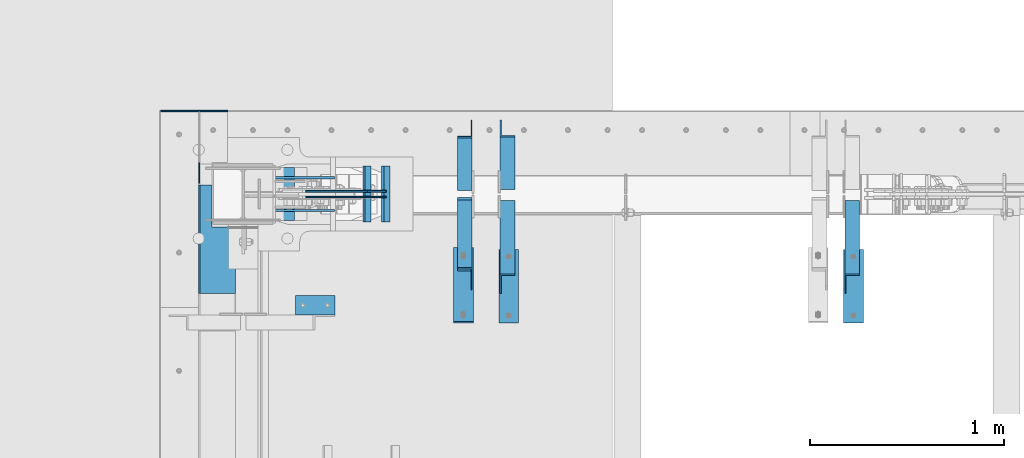
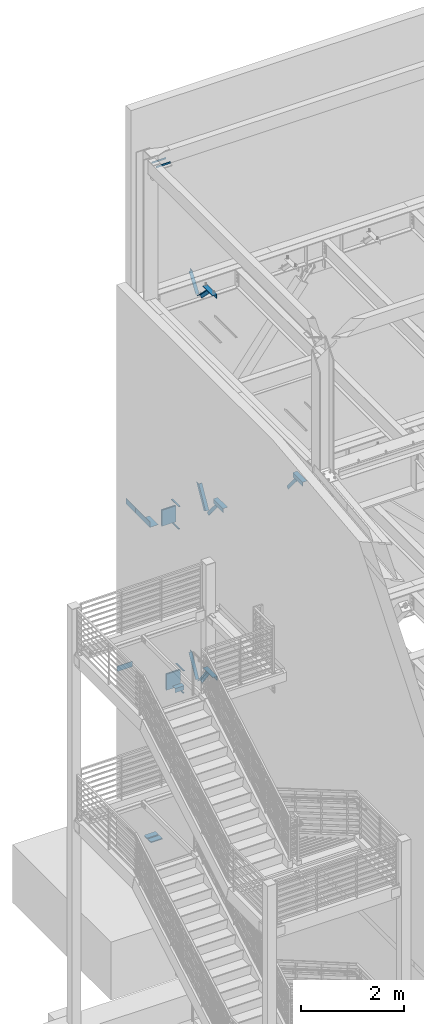
# One storey, part 882 of 1179: 20 beams, 7 members, 23 elements without a shape of their own.
"""IFC2X3 building model written with IfcOpenShell, lengths in millimetres."""

from ifc_helpers import new_model, si_unit, frame, origin_with_axes, place, context, subcontext, project, spatial, faceted_brep, material, type_object, element, aggregate, save


model = new_model("IFC2X3")

# Units and contexts
model_context = context("Model", 3, precision=1e-05, world=origin_with_axes())
body_context = subcontext(model_context, "Body", "Model", "MODEL_VIEW")
ifc_project = project(units=[si_unit("LENGTHUNIT", "METRE", prefix="MILLI"), si_unit("AREAUNIT", "SQUARE_METRE"), si_unit("VOLUMEUNIT", "CUBIC_METRE"), si_unit("MASSUNIT", "GRAM", prefix="KILO"), si_unit("TIMEUNIT", "SECOND"), si_unit("PLANEANGLEUNIT", "RADIAN"), si_unit("SOLIDANGLEUNIT", "STERADIAN"), si_unit("THERMODYNAMICTEMPERATUREUNIT", "DEGREE_CELSIUS"), si_unit("LUMINOUSINTENSITYUNIT", "LUMEN")], contexts=[model_context])

# Site, building, storey
site_placement = place(None, origin_with_axes())
site = spatial("IfcSite", under=ifc_project, at=site_placement, CompositionType="ELEMENT")
building_placement = place(site_placement, origin_with_axes())
building = spatial("IfcBuilding", under=site, at=building_placement, Name="Undefined", CompositionType="ELEMENT")
storey_placement = place(building_placement, origin_with_axes())
storey = spatial("IfcBuildingStorey", under=building, at=storey_placement, Name="Undefined", CompositionType="ELEMENT", Elevation=0.0)

# Assembly, member
assembly_1_placement = place(storey_placement, origin_with_axes())
assembly_1 = element("IfcElementAssembly", 1, at=assembly_1_placement, inside=storey, Name="ANGLE", AssemblyPlace="NOTDEFINED", PredefinedType="RIGID_FRAME")
ifc_material_1 = material(Name="STEEL/A36")
member_type = type_object("IfcMemberType", Name="L3X3X1/4", PredefinedType="NOTDEFINED")
member_1_placement = place(assembly_1_placement, frame((1574.8, 41248.3636551318, 12707.4244380128), z_axis=(0.0, 0.821716663099518, -0.569896241069015), x_axis=(0.0, 0.569896241069016, 0.821716663099518)))
member_1 = element("IfcMember", 2, at=member_1_placement, type_object=member_type, material=ifc_material_1, Name="ANGLE", ObjectType="L3X3X1/4", context=body_context, shape_type="Brep", body=[
    faceted_brep([(0.0, -38.0999999999985, -38.0999999999999), (0.0, -38.0999999999985, -31.75), (0.0, 31.75, -31.75), (0.0, 31.75, 38.1000000000004), (0.0, 38.0999999999985, 38.0999999999999), (0.0, 38.0999999999985, -38.0999999999999), (527.418547333735, 31.75, 38.0999999993364), (527.418547333735, 38.1000000000004, 38.0999999993364), (474.570533511644, 38.1000000000004, -38.1000000006607), (474.570533511644, -38.1000000000004, -38.1000000006607), (478.974534663488, -38.1000000000004, -31.7500000006621), (478.974534663488, 31.75, -31.7500000006621)], [[[0, 1, 2, 3, 4, 5]], [[4, 3, 6, 7]], [[5, 4, 7, 8]], [[0, 5, 8, 9]], [[1, 0, 9, 10]], [[2, 1, 10, 11]], [[3, 2, 11, 6]], [[10, 9, 8, 7, 6, 11]]]),
])
aggregate(assembly_1, [member_1])

assembly_2_placement = place(storey_placement, origin_with_axes())
assembly_2 = element("IfcElementAssembly", 3, at=assembly_2_placement, inside=storey, Name="ANGLE", AssemblyPlace="NOTDEFINED", PredefinedType="RIGID_FRAME")
member_2_placement = place(assembly_2_placement, frame((3573.22978739681, 41137.0679040265, 7518.83524528677), z_axis=(0.0, -0.767806695844832, -0.640681572870519), x_axis=(0.0, -0.640681572870519, 0.767806695844831)))
member_2 = element("IfcMember", 4, at=member_2_placement, type_object=member_type, material=ifc_material_1, Name="ANGLE", ObjectType="L3X3X1/4", context=body_context, shape_type="Brep", body=[
    faceted_brep([(0.0, 38.0999999999985, -38.0999999999999), (0.0, 38.0999999999985, 38.0999999999999), (655.633410548446, 38.1000000000004, 38.0999999994965), (592.049781860664, 38.1000000000004, -38.1000000005733), (0.0, 31.75, 38.1000000000004), (655.633410548446, 31.75, 38.0999999994965), (0.0, 31.75, -31.75), (597.348417584646, 31.75, -31.7500000005675), (0.0, -38.0999999999985, -31.75), (597.348417584646, -38.1000000000004, -31.7500000005675), (0.0, -38.0999999999985, -38.0999999999999), (592.049781860664, -38.1000000000004, -38.1000000005733)], [[[0, 1, 2, 3]], [[1, 4, 5, 2]], [[4, 6, 7, 5]], [[6, 8, 9, 7]], [[8, 10, 11, 9]], [[10, 0, 3, 11]], [[5, 7, 9, 11, 3, 2]], [[10, 8, 6, 4, 1, 0]]]),
])
aggregate(assembly_2, [member_2])

assembly_3_placement = place(storey_placement, origin_with_axes())
assembly_3 = element("IfcElementAssembly", 5, at=assembly_3_placement, inside=storey, Name="ANGLE", AssemblyPlace="NOTDEFINED", PredefinedType="RIGID_FRAME")
member_3_placement = place(assembly_3_placement, frame((1795.22978739681, 41656.0, 8227.31342088179), z_axis=(0.0, 0.872675718014636, -0.488300206008189), x_axis=(0.0, -0.48830020600819, -0.872675718014636)))
member_3 = element("IfcMember", 6, at=member_3_placement, type_object=member_type, material=ifc_material_1, Name="ANGLE", ObjectType="L3X3X1/4", context=body_context, shape_type="Brep", body=[
    faceted_brep([(266.09845322503, 38.1000000000004, -38.1000000001477), (223.461222774196, 38.1000000000004, 38.0999999997293), (818.212094408347, 38.1000000000004, 38.0999999992346), (818.21209440822, 38.1000000000004, -38.100000000617), (223.461222774196, 31.75, 38.0999999997293), (818.212094408347, 31.75, 38.0999999992346), (262.545350687458, 31.75, -31.7500000001601), (818.212094408227, 31.75, -31.7500000006257), (262.545350687458, -38.1000000000004, -31.7500000001601), (818.212094408227, -38.1000000000004, -31.7500000006257), (266.09845322503, -38.1000000000004, -38.1000000001477), (818.21209440822, -38.1000000000004, -38.100000000617)], [[[0, 1, 2, 3]], [[1, 4, 5, 2]], [[4, 6, 7, 5]], [[6, 8, 9, 7]], [[8, 10, 11, 9]], [[10, 0, 3, 11]], [[5, 7, 9, 11, 3, 2]], [[10, 8, 6, 4, 1, 0]]]),
])
aggregate(assembly_3, [member_3])

assembly_4_placement = place(storey_placement, origin_with_axes())
assembly_4 = element("IfcElementAssembly", 7, at=assembly_4_placement, inside=storey, Name="ANGLE", AssemblyPlace="NOTDEFINED", PredefinedType="RIGID_FRAME")
member_4_placement = place(assembly_4_placement, frame((1795.22978739681, 41137.0679040265, 7518.83524528677), z_axis=(0.0, -0.767806695844832, -0.640681572870519), x_axis=(0.0, -0.640681572870519, 0.767806695844831)))
member_4 = element("IfcMember", 8, at=member_4_placement, type_object=member_type, material=ifc_material_1, Name="ANGLE", ObjectType="L3X3X1/4", context=body_context, shape_type="Brep", body=[
    faceted_brep([(0.0, 38.0999999999985, -38.0999999999999), (0.0, 38.0999999999985, 38.0999999999999), (655.633410548446, 38.1000000000004, 38.0999999994965), (592.049781860664, 38.1000000000004, -38.1000000005733), (0.0, 31.75, 38.1000000000004), (655.633410548446, 31.75, 38.0999999994965), (0.0, 31.75, -31.75), (597.348417584646, 31.75, -31.7500000005675), (0.0, -38.0999999999985, -31.75), (597.348417584646, -38.1000000000004, -31.7500000005675), (0.0, -38.0999999999985, -38.0999999999999), (592.049781860664, -38.1000000000004, -38.1000000005733)], [[[0, 1, 2, 3]], [[1, 4, 5, 2]], [[4, 6, 7, 5]], [[6, 8, 9, 7]], [[8, 10, 11, 9]], [[10, 0, 3, 11]], [[5, 7, 9, 11, 3, 2]], [[10, 8, 6, 4, 1, 0]]]),
])
aggregate(assembly_4, [member_4])

assembly_5_placement = place(storey_placement, origin_with_axes())
assembly_5 = element("IfcElementAssembly", 9, at=assembly_5_placement, inside=storey, Name="ANGLE", AssemblyPlace="NOTDEFINED", PredefinedType="RIGID_FRAME")
member_5_placement = place(assembly_5_placement, frame((1574.80000000002, 40722.5022996856, 4156.39103856133), z_axis=(0.0, -0.797785167426298, -0.602941810322185), x_axis=(0.0, 0.602941810322187, -0.797785167426297)))
member_5 = element("IfcMember", 10, at=member_5_placement, type_object=member_type, material=ifc_material_1, Name="ANGLE", ObjectType="L3X3X1/4", context=body_context, shape_type="Brep", body=[
    faceted_brep([(110.776215380578, 38.1000000000004, -38.1000000000058), (53.1865686658894, 38.1000000000004, 38.1000000001659), (690.351875241478, 38.1000000000004, 38.1000000007261), (690.351875241598, 38.1000000000004, -38.0999999994892), (53.1865686658894, 31.75, 38.1000000001659), (690.351875241478, 31.75, 38.1000000007261), (105.977078154352, 31.75, -31.7499999999927), (690.351875241595, 31.75, -31.7499999994689), (105.977078154352, -38.1000000000004, -31.7499999999927), (690.351875241595, -38.1000000000004, -31.7499999994689), (110.776215380578, -38.1000000000004, -38.1000000000058), (690.351875241598, -38.1000000000004, -38.0999999994892)], [[[0, 1, 2, 3]], [[1, 4, 5, 2]], [[4, 6, 7, 5]], [[6, 8, 9, 7]], [[8, 10, 11, 9]], [[10, 0, 3, 11]], [[5, 7, 9, 11, 3, 2]], [[10, 8, 6, 4, 1, 0]]]),
])
aggregate(assembly_5, [member_5])

assembly_6_placement = place(storey_placement, origin_with_axes())
assembly_6 = element("IfcElementAssembly", 11, at=assembly_6_placement, inside=storey, Name="ANGLE", AssemblyPlace="NOTDEFINED", PredefinedType="RIGID_FRAME")
member_6_placement = place(assembly_6_placement, frame((1574.8, 41256.8365589201, 3601.33927004389), z_axis=(0.0, 0.873306509536275, -0.487171161299155), x_axis=(0.0, 0.487171161299156, 0.873306509536275)))
member_6 = element("IfcMember", 12, at=member_6_placement, type_object=member_type, material=ifc_material_1, Name="ANGLE", ObjectType="L3X3X1/4", context=body_context, shape_type="Brep", body=[
    faceted_brep([(0.0, 38.0999999999985, -38.0999999999999), (0.0, 38.0999999999985, 38.0999999999999), (594.661720177039, 38.1000000000004, 38.1000000011991), (552.153801037723, 38.1000000000004, -38.0999999989144), (0.0, 31.75, 38.1000000000004), (594.661720177039, 31.75, 38.1000000011991), (0.0, 31.75, -31.75), (555.696127632669, 31.75, -31.7499999988941), (0.0, -38.0999999999985, -31.75), (555.696127632669, -38.1000000000004, -31.7499999988941), (0.0, -38.0999999999985, -38.0999999999999), (552.153801037723, -38.1000000000004, -38.0999999989144)], [[[0, 1, 2, 3]], [[1, 4, 5, 2]], [[4, 6, 7, 5]], [[6, 8, 9, 7]], [[8, 10, 11, 9]], [[10, 0, 3, 11]], [[5, 7, 9, 11, 3, 2]], [[10, 8, 6, 4, 1, 0]]]),
])
aggregate(assembly_6, [member_6])

assembly_7_placement = place(storey_placement, origin_with_axes())
assembly_7 = element("IfcElementAssembly", 13, at=assembly_7_placement, inside=storey, Name="ANGLE", AssemblyPlace="NOTDEFINED", PredefinedType="RIGID_FRAME")
member_7_placement = place(assembly_7_placement, frame((1574.80000000002, 40704.7386537875, 13150.1502196524), z_axis=(0.0, -0.706388288025418, -0.707824545025474), x_axis=(0.0, 0.707824545025473, -0.706388288025419)))
member_7 = element("IfcMember", 14, at=member_7_placement, type_object=member_type, material=ifc_material_1, Name="ANGLE", ObjectType="L3X3X1/4", context=body_context, shape_type="Brep", body=[
    faceted_brep([(634.184990526992, 31.75, 38.0999999999767), (634.184990526996, 31.75, -31.7499999999636), (634.184990526996, -38.0999999999985, -31.7499999999636), (634.184990526996, -38.0999999999985, -38.0999999999549), (634.184990526996, 38.0999999999985, -38.0999999999549), (634.184990526992, 38.0999999999985, 38.0999999999767), (113.596638248473, -38.0999999999985, -38.0999999999549), (113.596638248473, 38.0999999999985, -38.0999999999549), (37.2417053522113, 38.0999999999985, 38.0999999999694), (37.2417053522113, 31.75, 38.0999999999694), (107.233727173789, 31.75, -31.7499999999709), (107.233727173789, -38.0999999999985, -31.7499999999709)], [[[0, 1, 2, 3, 4, 5]], [[4, 3, 6, 7]], [[5, 4, 7, 8]], [[0, 5, 8, 9]], [[1, 0, 9, 10]], [[2, 1, 10, 11]], [[3, 2, 11, 6]], [[10, 9, 8, 7, 6, 11]]]),
])
aggregate(assembly_7, [member_7])

# Assembly, beam
assembly_8_placement = place(storey_placement, origin_with_axes())
assembly_8 = element("IfcElementAssembly", 15, at=assembly_8_placement, inside=storey, Name="BEAM", AssemblyPlace="NOTDEFINED", PredefinedType="RIGID_FRAME")
ifc_material_2 = material(Name="STEEL/A572-GR.50")
beam_type_1 = type_object("IfcBeamType", PredefinedType="NOTDEFINED")
beam_1_placement = place(assembly_8_placement, frame((1080.89774757307, 41198.7999633791, 7459.6625), z_axis=(0.0, 1.0, 0.0), x_axis=(-1.0, 0.0, 0.0)))
beam_1 = element("IfcBeam", 16, at=beam_1_placement, type_object=beam_type_1, material=ifc_material_2, Name="PLATE", context=body_context, shape_type="Brep", body=[
    faceted_brep([(0.0, 4.76249999999982, -144.462500000001), (0.0, 4.76249999999982, 144.462500000001), (31.7500000000036, 4.76249999999982, 144.462500000001), (31.7500000000036, 4.76249999999982, -144.462500000001), (0.0, -4.76249999999982, 144.462500000001), (31.7500000000036, -4.76249999999982, 144.462500000001), (0.0, -4.76249999999982, -144.462500000001), (31.7500000000036, -4.76249999999982, -144.462500000001)], [[[0, 1, 2, 3]], [[1, 4, 5, 2]], [[4, 6, 7, 5]], [[6, 0, 3, 7]], [[5, 7, 3, 2]], [[6, 4, 1, 0]]]),
])

assembly_9_placement = place(storey_placement, origin_with_axes())
assembly_9 = element("IfcElementAssembly", 17, at=assembly_9_placement, inside=storey, Name="BEAM", AssemblyPlace="NOTDEFINED", PredefinedType="RIGID_FRAME")
beam_2_placement = place(assembly_9_placement, frame((1177.731069138, 41198.8000366209, 3548.0625), z_axis=(0.0, -1.0, 0.0), x_axis=(-1.0, 0.0, 0.0)))
beam_2 = element("IfcBeam", 18, at=beam_2_placement, type_object=beam_type_1, material=ifc_material_2, Name="PLATE", context=body_context, shape_type="Brep", body=[
    faceted_brep([(0.0, 4.76249999999982, -144.462500000001), (0.0, 4.76249999999982, 144.462500000001), (31.7500000000036, 4.76249999999982, 144.462500000001), (31.7500000000036, 4.76249999999982, -144.462500000001), (0.0, -4.76249999999982, 144.462500000001), (31.7500000000036, -4.76249999999982, 144.462500000001), (0.0, -4.76249999999982, -144.462500000001), (31.7500000000036, -4.76249999999982, -144.462500000001)], [[[0, 1, 2, 3]], [[1, 4, 5, 2]], [[4, 6, 7, 5]], [[6, 0, 3, 7]], [[5, 7, 3, 2]], [[6, 4, 1, 0]]]),
])

# Beam
beam_3_placement = place(assembly_8_placement, frame((1092.0098311487, 41198.7999633791, 7984.72549025941), z_axis=(0.0, 1.0, 0.0), x_axis=(-1.0, 0.0, 0.0)))
beam_3 = element("IfcBeam", 19, at=beam_3_placement, type_object=beam_type_1, material=ifc_material_2, Name="PLATE", context=body_context, shape_type="Brep", body=[
    faceted_brep([(0.0, 4.76249999999982, -144.462500000001), (0.0, 4.76249999999982, 144.462500000001), (31.7500000000036, 4.76249999999982, 144.462500000001), (31.7500000000036, 4.76249999999982, -144.462500000001), (0.0, -4.76249999999982, 144.462500000001), (31.7500000000036, -4.76249999999982, 144.462500000001), (0.0, -4.76249999999982, -144.462500000001), (31.7500000000036, -4.76249999999982, -144.462500000001)], [[[0, 1, 2, 3]], [[1, 4, 5, 2]], [[4, 6, 7, 5]], [[6, 0, 3, 7]], [[5, 7, 3, 2]], [[6, 4, 1, 0]]]),
])

beam_4_placement = place(assembly_9_placement, frame((1188.8431525714, 41198.8000366209, 4073.128), z_axis=(0.0, -1.0, 0.0), x_axis=(-1.0, 0.0, 0.0)))
beam_4 = element("IfcBeam", 20, at=beam_4_placement, type_object=beam_type_1, material=ifc_material_2, Name="PLATE", context=body_context, shape_type="Brep", body=[
    faceted_brep([(0.0, 4.76249999999982, -144.462500000001), (0.0, 4.76249999999982, 144.462500000001), (31.7500000000036, 4.76249999999982, 144.462500000001), (31.7500000000036, 4.76249999999982, -144.462500000001), (0.0, -4.76249999999982, 144.462500000001), (31.7500000000036, -4.76249999999982, 144.462500000001), (0.0, -4.76249999999982, -144.462500000001), (31.7500000000036, -4.76249999999982, -144.462500000001)], [[[0, 1, 2, 3]], [[1, 4, 5, 2]], [[4, 6, 7, 5]], [[6, 0, 3, 7]], [[5, 7, 3, 2]], [[6, 4, 1, 0]]]),
])

aggregate(assembly_9, [beam_2, beam_4])

# Assembly, beam
assembly_10_placement = place(storey_placement, origin_with_axes())
assembly_10 = element("IfcElementAssembly", 21, at=assembly_10_placement, inside=storey, Name="ANGLE", AssemblyPlace="NOTDEFINED", PredefinedType="RIGID_FRAME")
beam_type_2 = type_object("IfcBeamType", Name="L4X4X1/4", PredefinedType="NOTDEFINED")
beam_5_placement = place(assembly_10_placement, frame((3579.57978739681, 40533.6375, 7962.9), z_axis=(1.0, 0.0, 0.0), x_axis=(0.0, 1.0, 0.0)))
beam_5 = element("IfcBeam", 22, at=beam_5_placement, type_object=beam_type_2, material=ifc_material_1, Name="ANGLE", ObjectType="L4X4X1/4", context=body_context, shape_type="Brep", body=[
    faceted_brep([(1.90993887372315e-11, 50.8000000000002, -50.8000000000002), (1.90993887372315e-11, 50.8000000000002, 50.8000000000002), (381.0, 50.8000000000002, 50.7999999999993), (381.0, 50.8000000000002, -50.7999999999993), (0.0, 44.4500000000007, 50.8000000000002), (381.0, 44.4499999999998, 50.7999999999993), (0.0, 44.4500000000007, -44.4499999999998), (381.0, 44.4499999999998, -44.4500000000007), (0.0, -50.7999999999993, -44.4499999999998), (381.0, -50.8000000000002, -44.4500000000007), (-1.81898940354586e-11, -50.7999999999997, -50.8000000000002), (381.0, -50.8000000000002, -50.7999999999993)], [[[0, 1, 2, 3]], [[1, 4, 5, 2]], [[4, 6, 7, 5]], [[6, 8, 9, 7]], [[8, 10, 11, 9]], [[10, 0, 3, 11]], [[5, 7, 9, 11, 3, 2]], [[10, 8, 6, 4, 1, 0]]]),
])
aggregate(assembly_10, [beam_5])

assembly_11_placement = place(storey_placement, origin_with_axes())
assembly_11 = element("IfcElementAssembly", 23, at=assembly_11_placement, inside=storey, Name="ANGLE", AssemblyPlace="NOTDEFINED", PredefinedType="RIGID_FRAME")
beam_6_placement = place(assembly_11_placement, frame((1801.57978739681, 40533.6375, 7962.9), z_axis=(1.0, 0.0, 0.0), x_axis=(0.0, 1.0, 0.0)))
beam_6 = element("IfcBeam", 24, at=beam_6_placement, type_object=beam_type_2, material=ifc_material_1, Name="ANGLE", ObjectType="L4X4X1/4", context=body_context, shape_type="Brep", body=[
    faceted_brep([(1.90993887372315e-11, 50.8000000000002, -50.8000000000002), (1.90993887372315e-11, 50.8000000000002, 50.8000000000002), (381.0, 50.8000000000002, 50.7999999999993), (381.0, 50.8000000000002, -50.7999999999993), (0.0, 44.4500000000007, 50.8000000000002), (381.0, 44.4499999999998, 50.7999999999993), (0.0, 44.4500000000007, -44.4499999999998), (381.0, 44.4499999999998, -44.4500000000007), (0.0, -50.7999999999993, -44.4499999999998), (381.0, -50.8000000000002, -44.4500000000007), (-1.81898940354586e-11, -50.7999999999997, -50.8000000000002), (381.0, -50.8000000000002, -50.7999999999993)], [[[0, 1, 2, 3]], [[1, 4, 5, 2]], [[4, 6, 7, 5]], [[6, 8, 9, 7]], [[8, 10, 11, 9]], [[10, 0, 3, 11]], [[5, 7, 9, 11, 3, 2]], [[10, 8, 6, 4, 1, 0]]]),
])
aggregate(assembly_11, [beam_6])

assembly_12_placement = place(storey_placement, origin_with_axes())
assembly_12 = element("IfcElementAssembly", 25, at=assembly_12_placement, inside=storey, Name="ANGLE", AssemblyPlace="NOTDEFINED", PredefinedType="RIGID_FRAME")
beam_7_placement = place(assembly_12_placement, frame((1568.44999999845, 40914.6375, 4051.3), z_axis=(-1.0, 0.0, 0.0), x_axis=(0.0, -1.0, 0.0)))
beam_7 = element("IfcBeam", 26, at=beam_7_placement, type_object=beam_type_2, material=ifc_material_1, Name="ANGLE", ObjectType="L4X4X1/4", context=body_context, shape_type="Brep", body=[
    faceted_brep([(1.90993887372315e-11, 50.8000000000002, -50.8000000000002), (1.90993887372315e-11, 50.8000000000002, 50.8000000000002), (381.0, 50.8000000000002, 50.7999999999993), (381.0, 50.8000000000002, -50.7999999999993), (0.0, 44.4500000000007, 50.8000000000002), (381.0, 44.4499999999998, 50.7999999999993), (0.0, 44.4500000000007, -44.4499999999998), (381.0, 44.4499999999998, -44.4500000000007), (0.0, -50.7999999999993, -44.4499999999998), (381.0, -50.8000000000002, -44.4500000000007), (-1.81898940354586e-11, -50.7999999999997, -50.8000000000002), (381.0, -50.8000000000002, -50.7999999999993)], [[[0, 1, 2, 3]], [[1, 4, 5, 2]], [[4, 6, 7, 5]], [[6, 8, 9, 7]], [[8, 10, 11, 9]], [[10, 0, 3, 11]], [[5, 7, 9, 11, 3, 2]], [[10, 8, 6, 4, 1, 0]]]),
])
aggregate(assembly_12, [beam_7])

assembly_13_placement = place(storey_placement, origin_with_axes())
assembly_13 = element("IfcElementAssembly", 27, at=assembly_13_placement, inside=storey, Name="ANGLE", AssemblyPlace="NOTDEFINED", PredefinedType="RIGID_FRAME")
beam_8_placement = place(assembly_13_placement, frame((701.59635534156, 40625.7125, 4051.3), z_axis=(0.0, 0.0, -1.0), x_axis=(1.0, 0.0, 0.0)))
beam_8 = element("IfcBeam", 28, at=beam_8_placement, type_object=beam_type_2, material=ifc_material_1, Name="ANGLE", ObjectType="L4X4X1/4", context=body_context, shape_type="Brep", body=[
    faceted_brep([(1.90993887372315e-11, 50.8000000000002, -50.8000000000002), (1.90993887372315e-11, 50.8000000000002, 50.8000000000002), (203.200000000001, 50.7999999999993, 50.8000000000002), (203.200000000001, 50.7999999999993, -50.8000000000002), (0.0, 44.4500000000007, 50.8000000000002), (203.200000000001, 44.4500000000007, 50.8000000000002), (0.0, 44.4500000000007, -44.4499999999998), (203.200000000001, 44.4500000000007, -44.4499999999998), (0.0, -50.7999999999993, -44.4499999999998), (203.200000000001, -50.7999999999993, -44.4499999999998), (-1.81898940354586e-11, -50.7999999999997, -50.8000000000002), (203.200000000001, -50.7999999999993, -50.8000000000002)], [[[0, 1, 2, 3]], [[1, 4, 5, 2]], [[4, 6, 7, 5]], [[6, 8, 9, 7]], [[8, 10, 11, 9]], [[10, 0, 3, 11]], [[5, 7, 9, 11, 3, 2]], [[10, 8, 6, 4, 1, 0]]]),
])
aggregate(assembly_13, [beam_8])

assembly_14_placement = place(storey_placement, origin_with_axes())
assembly_14 = element("IfcElementAssembly", 29, at=assembly_14_placement, inside=storey, Name="ANGLE", AssemblyPlace="NOTDEFINED", PredefinedType="RIGID_FRAME")
beam_9_placement = place(assembly_14_placement, frame((1568.44999999795, 40924.1624999532, 13068.3), z_axis=(-1.0, 0.0, 0.0), x_axis=(0.0, -1.0, 0.0)))
beam_9 = element("IfcBeam", 30, at=beam_9_placement, type_object=beam_type_2, material=ifc_material_1, Name="ANGLE", ObjectType="L4X4X1/4", context=body_context, shape_type="Brep", body=[
    faceted_brep([(1.90993887372315e-11, 50.8000000000002, -50.8000000000002), (1.90993887372315e-11, 50.8000000000002, 50.8000000000002), (381.0, 50.8000000000002, 50.7999999999993), (381.0, 50.8000000000002, -50.7999999999993), (0.0, 44.4500000000007, 50.8000000000002), (381.0, 44.4499999999998, 50.7999999999993), (0.0, 44.4500000000007, -44.4499999999998), (381.0, 44.4499999999998, -44.4500000000007), (0.0, -50.7999999999993, -44.4499999999998), (381.0, -50.8000000000002, -44.4500000000007), (-1.81898940354586e-11, -50.7999999999997, -50.8000000000002), (381.0, -50.8000000000002, -50.7999999999993)], [[[0, 1, 2, 3]], [[1, 4, 5, 2]], [[4, 6, 7, 5]], [[6, 8, 9, 7]], [[8, 10, 11, 9]], [[10, 0, 3, 11]], [[5, 7, 9, 11, 3, 2]], [[10, 8, 6, 4, 1, 0]]]),
])
aggregate(assembly_14, [beam_9])

assembly_15_placement = place(storey_placement, origin_with_axes())
assembly_15 = element("IfcElementAssembly", 31, at=assembly_15_placement, inside=storey, Name="BEAM", AssemblyPlace="NOTDEFINED", PredefinedType="RIGID_FRAME")
beam_type_3 = type_object("IfcBeamType", PredefinedType="NOTDEFINED")
beam_10_placement = place(assembly_15_placement, frame((392.112506527683, 40967.2000448903, 8016.875), z_axis=(0.0, 1.0, 0.0), x_axis=(-1.0, 0.0, 0.0)))
beam_10 = element("IfcBeam", 32, at=beam_10_placement, type_object=beam_type_3, material=ifc_material_1, Name="BENT_PLATE", context=body_context, shape_type="Brep", body=[
    faceted_brep([(120.650006983258, -3.17500003705936, 61.7374548812804), (120.65000678006, 3.17499996294009, 61.7374548812804), (9.51331458054483e-10, 3.17500000000109, 61.737455109811), (-1.00141051007085e-09, -3.17499999999927, 61.737455109811), (120.650007188255, -3.17500003705936, 279.399999987545), (120.650006985058, 3.17499996294009, 279.400000000162), (188.912479186577, -3.17500005802776, -279.399999999754), (-8.63337845657952e-10, -3.17499999999927, -279.400000000001), (1.08940412246739e-09, 3.17500000000109, -279.400000000001), (182.562478983384, 3.17499994392347, -279.399999999754), (182.562474919354, 130.175011973703, -279.399999999674), (188.912474919354, 130.175012176898, -279.399999999674), (182.562478982814, 3.17499994392347, 279.400000000242), (182.562474919115, 130.175011973354, 279.400000000322), (188.912474919115, 130.175012176549, 279.400000000329), (188.912479186007, -3.17500005802776, 279.400000000249)], [[[0, 1, 2, 3]], [[4, 5, 1, 0]], [[6, 7, 8, 9, 10, 11]], [[9, 12, 13, 10]], [[14, 11, 10, 13]], [[15, 6, 11, 14]], [[3, 7, 6, 15, 4, 0]], [[8, 7, 3, 2]], [[12, 9, 8, 2, 1, 5]], [[15, 14, 13, 12, 5, 4]]]),
])
aggregate(assembly_15, [beam_10])

# Beam
beam_type_4 = type_object("IfcBeamType", PredefinedType="NOTDEFINED")
beam_11_placement = place(assembly_8_placement, frame((206.375023065457, 41254.3625, 8083.55000610352), z_axis=(0.0, 0.0, 1.0), x_axis=(0.0, 1.0, 0.0)))
beam_11 = element("IfcBeam", 33, at=beam_11_placement, type_object=beam_type_4, material=ifc_material_1, Name="PLATE", context=body_context, shape_type="Brep", body=[
    faceted_brep([(369.887500284567, -3.17499999942083, -44.4499999999998), (350.837500284564, -3.17499999944994, -63.5), (350.837500284557, 3.17500000055225, -63.5), (369.887500284553, 3.17500000057771, -44.4499999999998), (0.0, 3.17499999999927, -63.5), (0.0, 3.17499999999927, 63.5), (369.887500284553, 3.17500000057771, 63.5), (0.0, -3.17499999999927, 63.5), (369.887500284567, -3.17499999942083, 63.5), (0.0, -3.17499999999927, -63.5)], [[[0, 1, 2, 3]], [[4, 5, 6, 3, 2]], [[5, 7, 8, 6]], [[8, 7, 9, 1, 0]], [[9, 4, 2, 1]], [[6, 8, 0, 3]], [[9, 7, 5, 4]]]),
])

aggregate(assembly_8, [beam_1, beam_3, beam_11])

# Assembly, beam
assembly_16_placement = place(storey_placement, origin_with_axes())
assembly_16 = element("IfcElementAssembly", 34, at=assembly_16_placement, inside=storey, Name="BEAM", AssemblyPlace="NOTDEFINED", PredefinedType="RIGID_FRAME")
beam_12_placement = place(assembly_16_placement, frame((6.35000241300018, 41627.425, 4171.95), z_axis=(0.0, 0.0, 1.0), x_axis=(1.0, 0.0, 0.0)))
beam_12 = element("IfcBeam", 35, at=beam_12_placement, type_object=beam_type_4, material=ifc_material_1, Name="PLATE", context=body_context, shape_type="Brep", body=[
    faceted_brep([(0.0, 3.17499999999995, -44.4499999999998), (19.0499999999993, 3.17499999999995, -63.5), (19.0499999999993, -3.17499999999995, -63.5), (0.0, -3.17499999999995, -44.4499999999998), (0.0, 3.17499999999927, 63.5), (346.074983411469, 3.17500000000291, 63.4999999999345), (346.074983411469, 3.17500000000291, -63.5000000000655), (0.0, -3.17499999999927, 63.5), (346.074983411469, -3.17500000000291, 63.4999999999345), (346.074983411469, -3.17500000000291, -63.5000000000655)], [[[0, 1, 2, 3]], [[4, 5, 6, 1, 0]], [[4, 7, 8, 5]], [[9, 8, 7, 3, 2]], [[6, 9, 2, 1]], [[8, 9, 6, 5]], [[7, 4, 0, 3]]]),
])
aggregate(assembly_16, [beam_12])

assembly_17_placement = place(storey_placement, origin_with_axes())
assembly_17 = element("IfcElementAssembly", 36, at=assembly_17_placement, inside=storey, Name="PLATE", AssemblyPlace="NOTDEFINED", PredefinedType="RIGID_FRAME")
beam_type_5 = type_object("IfcBeamType", PredefinedType="NOTDEFINED")
beam_13_placement = place(assembly_17_placement, frame((438.150000000001, 41274.2065, 258.098145338185), z_axis=(0.0, -1.0, 0.0), x_axis=(1.0, 0.0, 0.0)))
beam_13 = element("IfcBeam", 37, at=beam_13_placement, type_object=beam_type_5, material=ifc_material_2, Name="PLATE", context=body_context, shape_type="Brep", body=[
    faceted_brep([(22.2249999999985, -12.6999999999998, -61.1189999999997), (0.0, -12.6999999999998, -38.8940000000002), (0.0, 12.6999999999998, -38.8940000000002), (22.2249999999985, 12.6999999999998, -61.1189999999997), (0.0, 12.7, 61.1189999999988), (258.663236021439, 12.7, 61.1189999999988), (258.663234532112, 12.7, -61.1189999999988), (0.0, -12.7, 61.1189999999988), (258.663236021439, -12.7, 61.1189999999988), (258.663234532112, -12.7, -61.1189999999988)], [[[0, 1, 2, 3]], [[4, 5, 6, 3, 2]], [[4, 7, 8, 5]], [[9, 8, 7, 1, 0]], [[6, 9, 0, 3]], [[8, 9, 6, 5]], [[7, 4, 2, 1]]]),
])
aggregate(assembly_17, [beam_13])

assembly_18_placement = place(storey_placement, origin_with_axes())
assembly_18 = element("IfcElementAssembly", 38, at=assembly_18_placement, inside=storey, Name="PLATE", AssemblyPlace="NOTDEFINED", PredefinedType="RIGID_FRAME")
beam_14_placement = place(assembly_18_placement, frame((438.150000000001, 41123.3935, 258.098145338185), z_axis=(0.0, 1.0, 0.0), x_axis=(1.0, 0.0, 0.0)))
beam_14 = element("IfcBeam", 39, at=beam_14_placement, type_object=beam_type_5, material=ifc_material_2, Name="PLATE", context=body_context, shape_type="Brep", body=[
    faceted_brep([(22.2249999999985, -12.6999999999998, -61.1189999999997), (0.0, -12.6999999999998, -38.8940000000002), (0.0, 12.6999999999998, -38.8940000000002), (22.2249999999985, 12.6999999999998, -61.1189999999997), (0.0, 12.7, 61.1189999999988), (258.663236021439, 12.7, 61.1189999999988), (258.663234532112, 12.7, -61.1189999999988), (0.0, -12.7, 61.1189999999988), (258.663236021439, -12.7, 61.1189999999988), (258.663234532112, -12.7, -61.1189999999988)], [[[0, 1, 2, 3]], [[4, 5, 6, 3, 2]], [[4, 7, 8, 5]], [[9, 8, 7, 1, 0]], [[6, 9, 0, 3]], [[8, 9, 6, 5]], [[7, 4, 2, 1]]]),
])
aggregate(assembly_18, [beam_14])

# Assembly, beams
assembly_19_placement = place(storey_placement, origin_with_axes())
assembly_19 = element("IfcElementAssembly", 40, at=assembly_19_placement, inside=storey, Name="COLUMN", AssemblyPlace="NOTDEFINED", PredefinedType="RIGID_FRAME")
beam_type_6 = type_object("IfcBeamType", PredefinedType="NOTDEFINED")
beam_15_placement = place(assembly_19_placement, frame((903.287500000003, 41114.6625, 16141.7), z_axis=(0.0, 0.0, 1.0), x_axis=(-1.0, 0.0, 0.0)))
beam_15 = element("IfcBeam", 41, at=beam_15_placement, type_object=beam_type_6, material=ifc_material_1, Name="PLATE", context=body_context, shape_type="Brep", body=[
    faceted_brep([(0.0, 6.34999999999854, -19.0499999999993), (0.0, 6.35000000000036, 19.0499999999993), (317.5, 6.34999999999854, 19.0499999999993), (317.5, 6.34999999999854, -19.0499999999993), (0.0, -6.35000000000036, 19.0499999999993), (317.5, -6.34999999999854, 19.0499999999993), (0.0, -6.34999999999854, -19.0499999999993), (317.5, -6.34999999999854, -19.0499999999993)], [[[0, 1, 2, 3]], [[1, 4, 5, 2]], [[4, 6, 7, 5]], [[6, 0, 3, 7]], [[5, 7, 3, 2]], [[6, 4, 1, 0]]]),
])
beam_16_placement = place(assembly_19_placement, frame((903.287500000003, 41282.9375, 16141.7), z_axis=(0.0, 0.0, 1.0), x_axis=(-1.0, 0.0, 0.0)))
beam_16 = element("IfcBeam", 42, at=beam_16_placement, type_object=beam_type_6, material=ifc_material_1, Name="PLATE", context=body_context, shape_type="Brep", body=[
    faceted_brep([(0.0, 6.34999999999854, -19.0499999999993), (0.0, 6.35000000000036, 19.0499999999993), (317.5, 6.34999999999854, 19.0499999999993), (317.5, 6.34999999999854, -19.0499999999993), (0.0, -6.35000000000036, 19.0499999999993), (317.5, -6.34999999999854, 19.0499999999993), (0.0, -6.34999999999854, -19.0499999999993), (317.5, -6.34999999999854, -19.0499999999993)], [[[0, 1, 2, 3]], [[1, 4, 5, 2]], [[4, 6, 7, 5]], [[6, 0, 3, 7]], [[5, 7, 3, 2]], [[6, 4, 1, 0]]]),
])
aggregate(assembly_19, [beam_15, beam_16])

# Assembly, beam
assembly_20_placement = place(storey_placement, origin_with_axes())
assembly_20 = element("IfcElementAssembly", 43, at=assembly_20_placement, inside=storey, Name="PLATE", AssemblyPlace="NOTDEFINED", PredefinedType="RIGID_FRAME")
beam_type_7 = type_object("IfcBeamType", PredefinedType="NOTDEFINED")
beam_17_placement = place(assembly_20_placement, frame((755.459942286098, 41184.5127863882, 7739.06051692846), z_axis=(0.0, 0.0, -1.0), x_axis=(1.0, 0.0, 0.0)))
beam_17 = element("IfcBeam", 44, at=beam_17_placement, type_object=beam_type_7, material=ifc_material_2, Name="PLATE", context=body_context, shape_type="Brep", body=[
    faceted_brep([(0.0, 4.76249999999709, -190.5), (0.0, 4.76249999999709, 190.5), (317.499999999995, 4.76250000000073, 190.500000000051), (317.500000000042, 4.76250000000073, -190.499999999973), (0.0, -4.76249999999709, 190.5), (317.499999999995, -4.76250000000073, 190.500000000051), (0.0, -4.76249999999709, -190.5), (317.500000000042, -4.76250000000073, -190.499999999973)], [[[0, 1, 2, 3]], [[1, 4, 5, 2]], [[4, 6, 7, 5]], [[6, 0, 3, 7]], [[5, 7, 3, 2]], [[6, 4, 1, 0]]]),
])
aggregate(assembly_20, [beam_17])

assembly_21_placement = place(storey_placement, origin_with_axes())
assembly_21 = element("IfcElementAssembly", 45, at=assembly_21_placement, inside=storey, Name="PLATE", AssemblyPlace="NOTDEFINED", PredefinedType="RIGID_FRAME")
beam_18_placement = place(assembly_21_placement, frame((1072.95983100647, 41213.0872136118, 7739.0625), z_axis=(0.0, 0.0, -1.0), x_axis=(-1.0, 0.0, 0.0)))
beam_18 = element("IfcBeam", 46, at=beam_18_placement, type_object=beam_type_7, material=ifc_material_2, Name="PLATE", context=body_context, shape_type="Brep", body=[
    faceted_brep([(0.0, 4.76249999999709, -190.5), (0.0, 4.76249999999709, 190.5), (317.499999999995, 4.76250000000073, 190.500000000051), (317.500000000042, 4.76250000000073, -190.499999999973), (0.0, -4.76249999999709, 190.5), (317.499999999995, -4.76250000000073, 190.500000000051), (0.0, -4.76249999999709, -190.5), (317.500000000042, -4.76250000000073, -190.499999999973)], [[[0, 1, 2, 3]], [[1, 4, 5, 2]], [[4, 6, 7, 5]], [[6, 0, 3, 7]], [[5, 7, 3, 2]], [[6, 4, 1, 0]]]),
])
aggregate(assembly_21, [beam_18])

assembly_22_placement = place(storey_placement, origin_with_axes())
assembly_22 = element("IfcElementAssembly", 47, at=assembly_22_placement, inside=storey, Name="PLATE", AssemblyPlace="NOTDEFINED", PredefinedType="RIGID_FRAME")
beam_19_placement = place(assembly_22_placement, frame((1169.79315562315, 41184.5125, 3827.46249389647), z_axis=(0.0, 0.0, -1.0), x_axis=(-1.0, 0.0, 0.0)))
beam_19 = element("IfcBeam", 48, at=beam_19_placement, type_object=beam_type_7, material=ifc_material_2, Name="PLATE", context=body_context, shape_type="Brep", body=[
    faceted_brep([(0.0, 4.76249999999709, -190.5), (0.0, 4.76249999999709, 190.5), (317.499999999995, 4.76250000000073, 190.500000000051), (317.500000000042, 4.76250000000073, -190.499999999973), (0.0, -4.76249999999709, 190.5), (317.499999999995, -4.76250000000073, 190.500000000051), (0.0, -4.76249999999709, -190.5), (317.500000000042, -4.76250000000073, -190.499999999973)], [[[0, 1, 2, 3]], [[1, 4, 5, 2]], [[4, 6, 7, 5]], [[6, 0, 3, 7]], [[5, 7, 3, 2]], [[6, 4, 1, 0]]]),
])
aggregate(assembly_22, [beam_19])

assembly_23_placement = place(storey_placement, origin_with_axes())
assembly_23 = element("IfcElementAssembly", 49, at=assembly_23_placement, inside=storey, Name="PLATE", AssemblyPlace="NOTDEFINED", PredefinedType="RIGID_FRAME")
beam_20_placement = place(assembly_23_placement, frame((852.293155623154, 41213.0872136118, 3827.46249389647), z_axis=(0.0, 0.0, -1.0), x_axis=(1.0, 0.0, 0.0)))
beam_20 = element("IfcBeam", 50, at=beam_20_placement, type_object=beam_type_7, material=ifc_material_2, Name="PLATE", context=body_context, shape_type="Brep", body=[
    faceted_brep([(0.0, 4.76249999999709, -190.5), (0.0, 4.76249999999709, 190.5), (317.499999999995, 4.76250000000073, 190.500000000051), (317.500000000042, 4.76250000000073, -190.499999999973), (0.0, -4.76249999999709, 190.5), (317.499999999995, -4.76250000000073, 190.500000000051), (0.0, -4.76249999999709, -190.5), (317.500000000042, -4.76250000000073, -190.499999999973)], [[[0, 1, 2, 3]], [[1, 4, 5, 2]], [[4, 6, 7, 5]], [[6, 0, 3, 7]], [[5, 7, 3, 2]], [[6, 4, 1, 0]]]),
])
aggregate(assembly_23, [beam_20])

save(model, "model.ifc")
